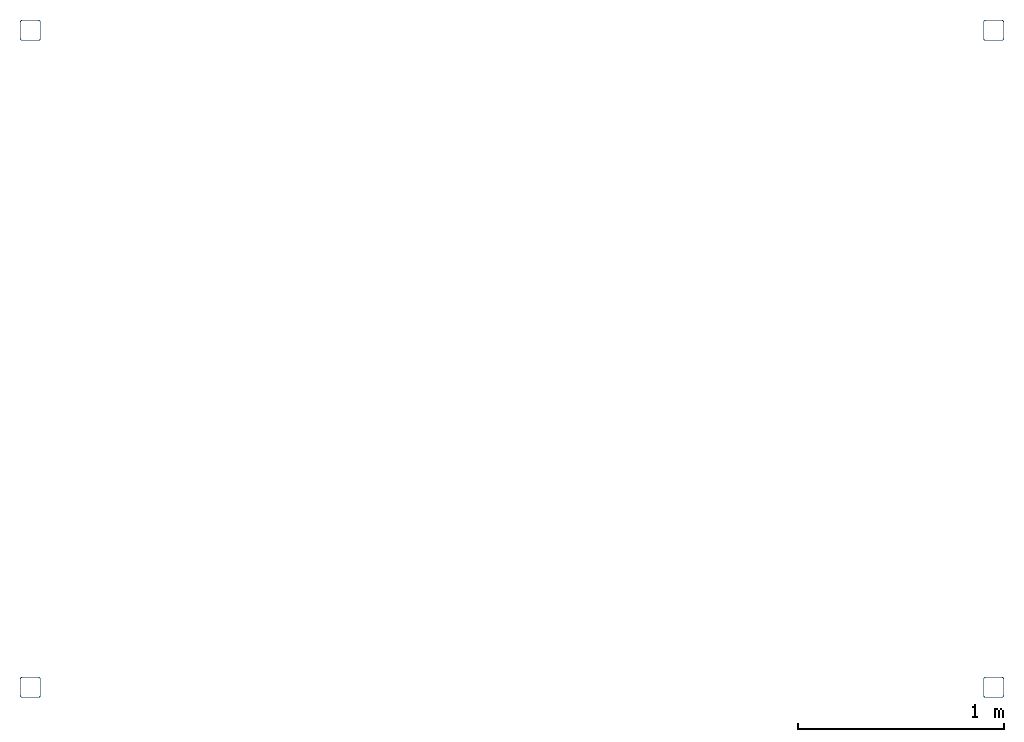
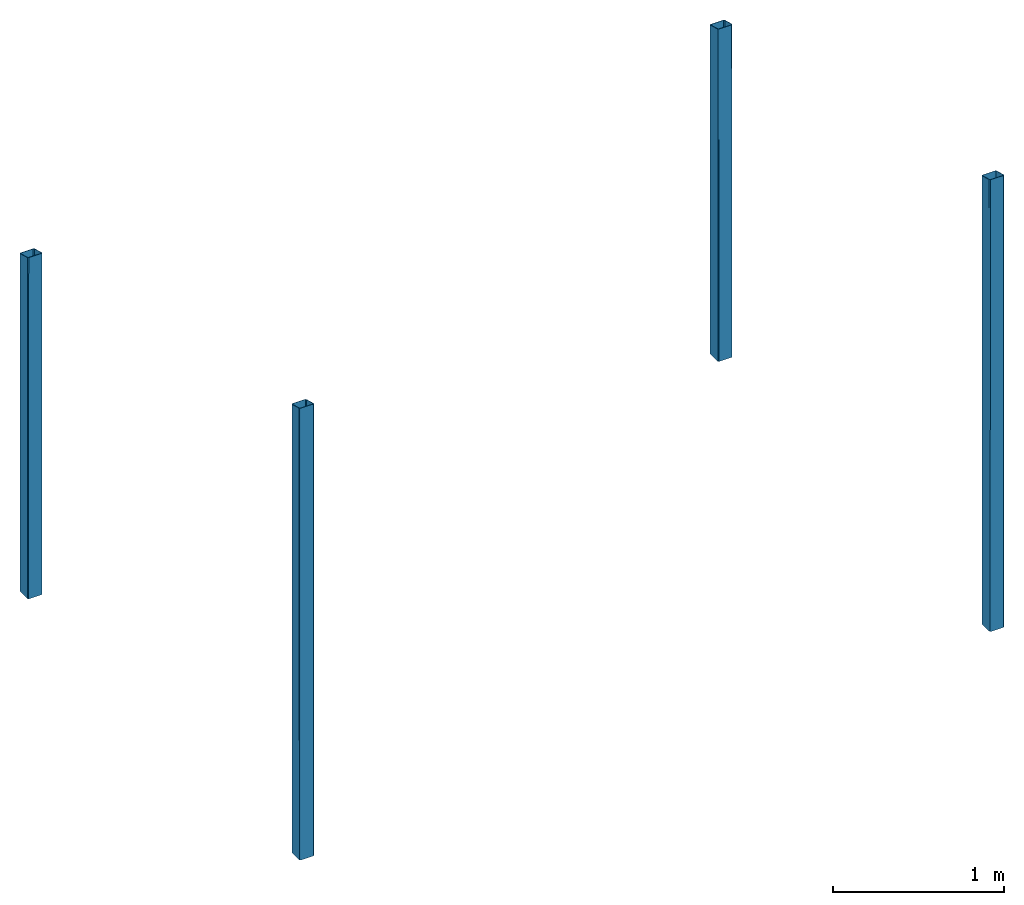
"""IFC4X3_ADD2 building model written with IfcOpenShell, lengths in millimetres."""

import ifcopenshell
import ifcopenshell.guid

model = None  # the IFC model being written
_history = None  # IfcOwnerHistory: only IFC2X3 demands one
_inside = {}  # id of a spatial element -> (the spatial element, [elements in it])
_under = {}  # id of a project, library or spatial element -> (it, [spatial elements below it])
_declared = {}  # id of a project -> (the project, [libraries it declares])
_typed = {}  # id of a type object -> (the type object, [elements of that type])
_made_of = {}  # id of a material, layer set ... -> (it, [elements and type objects made of it])


def new_model(schema):
    """Start an empty IFC model of exactly this schema.

    Asked for "IFC4X3", IfcOpenShell would pick the latest addendum, in which some entities
    have other attributes; the version numbers below select the first issue.
    IFC2X3 requires an IfcOwnerHistory on every rooted entity: one is made here for all.
    """
    global model, _history
    if schema == "IFC4X3":
        model = ifcopenshell.file(schema_version=(4, 3, 0, 0))
    else:
        model = ifcopenshell.file(schema=schema)
    _inside.clear()
    _under.clear()
    _declared.clear()
    _typed.clear()
    _made_of.clear()
    _history = None
    if model.schema == "IFC2X3":
        org = make("IfcOrganization", Name="unknown")
        user = make(
            "IfcPersonAndOrganization",
            ThePerson=make("IfcPerson", FamilyName="unknown"),
            TheOrganization=org,
        )
        app = make(
            "IfcApplication",
            ApplicationDeveloper=org,
            Version="unknown",
            ApplicationFullName="unknown",
            ApplicationIdentifier="unknown",
        )
        _history = make(
            "IfcOwnerHistory",
            OwningUser=user,
            OwningApplication=app,
            ChangeAction="ADDED",
            CreationDate=0,
        )
    return model


def make(cls, **values):
    """One entity of the class cls with the attributes given. An attribute that is None is left unset."""
    return model.create_entity(
        cls, **{name: value for name, value in values.items() if value is not None}
    )


def entity(cls, *values):
    """Any entity or typed value of the class cls, its attributes in the order of the schema. None: left unset."""
    e = model.create_entity(cls)
    for i, value in enumerate(values):
        if value is not None:
            e[i] = value
    return e


def rooted(cls, **values):
    """An entity with a GlobalId (a new one), such as an element, a storey or a relation."""
    return make(cls, GlobalId=ifcopenshell.guid.new(), OwnerHistory=_history, **values)


def si_unit(unit_type, name, prefix=None):
    """IfcSIUnit, for example si_unit("LENGTHUNIT", "METRE", prefix="MILLI")."""
    return make("IfcSIUnit", UnitType=unit_type, Prefix=prefix, Name=name)


def converted_unit(unit_type, name, factor, base, dimensions=None, offset=None):
    """IfcConversionBasedUnit, such as the inch: factor (a typed value) times the base unit."""
    return make(
        "IfcConversionBasedUnit"
        if offset is None
        else "IfcConversionBasedUnitWithOffset",
        ConversionOffset=offset,
        Dimensions=None
        if dimensions is None
        else entity("IfcDimensionalExponents", *dimensions),
        UnitType=unit_type,
        Name=name,
        ConversionFactor=make(
            "IfcMeasureWithUnit", ValueComponent=factor, UnitComponent=base
        ),
    )


def assignment(units):
    """IfcUnitAssignment: the units of a project."""
    return None if units is None else make("IfcUnitAssignment", Units=units)


def point(xyz):
    """IfcCartesianPoint."""
    return None if xyz is None else make("IfcCartesianPoint", Coordinates=xyz)


def direction(xyz):
    """IfcDirection."""
    return None if xyz is None else make("IfcDirection", DirectionRatios=xyz)


def frame(location, z_axis=None, x_axis=None):
    """IfcAxis2Placement3D, a coordinate frame: its origin and axes. An axis left out is left unset."""
    return make(
        "IfcAxis2Placement3D",
        Location=point(location),
        Axis=direction(z_axis),
        RefDirection=direction(x_axis),
    )


def frame_2d(location, x_axis=None):
    """IfcAxis2Placement2D, a coordinate frame in the plane: its origin and x axis."""
    return make(
        "IfcAxis2Placement2D", Location=point(location), RefDirection=direction(x_axis)
    )


def origin_with_axes():
    """The frame at (0, 0, 0) with the z axis (0, 0, 1) and the x axis (1, 0, 0) written out."""
    return frame((0.0, 0.0, 0.0), z_axis=(0.0, 0.0, 1.0), x_axis=(1.0, 0.0, 0.0))


def origin_2d_with_axis():
    """The frame at (0, 0) in the plane with the x axis (1, 0) written out."""
    return frame_2d((0.0, 0.0), x_axis=(1.0, 0.0))


def place(relative_to, where):
    """IfcLocalPlacement: puts the frame where relative to a parent placement (None: the world)."""
    return make(
        "IfcLocalPlacement", PlacementRelTo=relative_to, RelativePlacement=where
    )


def context(
    kind, dimensions, precision=None, world=None, true_north=None, identifier=None
):
    """IfcGeometricRepresentationContext, for example the 3D "Model" context."""
    return make(
        "IfcGeometricRepresentationContext",
        ContextIdentifier=identifier,
        ContextType=kind,
        CoordinateSpaceDimension=dimensions,
        Precision=precision,
        WorldCoordinateSystem=world,
        TrueNorth=true_north,
    )


def subcontext(parent, identifier, kind, view, scale=None):
    """IfcGeometricRepresentationSubContext, for example "Body" below "Model"."""
    return make(
        "IfcGeometricRepresentationSubContext",
        ContextIdentifier=identifier,
        ContextType=kind,
        ParentContext=parent,
        TargetScale=scale,
        TargetView=view,
    )


def project(units=None, contexts=None):
    """IfcProject with its units and contexts."""
    return rooted(
        "IfcProject",
        Name="project",
        RepresentationContexts=contexts,
        UnitsInContext=assignment(units),
    )


def spatial(cls, under=None, at=None, **own):
    """A site, building, storey or space (cls), placed at a placement, below another one or the project."""
    s = rooted(cls, ObjectPlacement=at, **own)
    if under is not None:
        _under.setdefault(under.id(), (under, []))[1].append(s)
    return s


def profile(cls, at=None, kind="AREA", **sizes):
    """A parametric profile (cls). Its sizes go by their IFC names, for example OverallWidth=200.0."""
    return make(cls, ProfileType=kind, Position=at, **sizes)


def hollow_rectangle(**sizes):
    """IfcRectangleHollowProfileDef."""
    return profile("IfcRectangleHollowProfileDef", **sizes)


def extrude(swept, where, along, depth):
    """IfcExtrudedAreaSolid: the profile swept, set in the frame where, extruded along a direction by depth."""
    return make(
        "IfcExtrudedAreaSolid",
        SweptArea=swept,
        Position=where,
        ExtrudedDirection=direction(along),
        Depth=depth,
    )


def clip(a, b, op="DIFFERENCE"):
    """IfcBooleanClippingResult: the solid a cut by the half space b."""
    return make(
        "IfcBooleanClippingResult", Operator=op, FirstOperand=a, SecondOperand=b
    )


def halfspace(plane, agree):
    """IfcHalfSpaceSolid: all space on one side of the plane z = 0 of the frame plane."""
    return make(
        "IfcHalfSpaceSolid",
        BaseSurface=make("IfcPlane", Position=plane),
        AgreementFlag=agree,
    )


def shape(context_of_items, identifier, shape_type, items):
    """IfcShapeRepresentation: the items that make up one representation, for example the "Body"."""
    return make(
        "IfcShapeRepresentation",
        ContextOfItems=context_of_items,
        RepresentationIdentifier=identifier,
        RepresentationType=shape_type,
        Items=items,
    )


def made_of(thing, what):
    """Note that an element or type object is made of a material, layer set ...; save() writes the relation."""
    if what is not None:
        _made_of.setdefault(what.id(), (what, []))[1].append(thing)
    return thing


def element(
    cls,
    number,
    at=None,
    inside=None,
    cuts=None,
    type_object=None,
    material=None,
    context=None,
    identifier="Body",
    shape_type=None,
    held_by="IfcProductDefinitionShape",
    body=None,
    shapes=None,
    **own,
):
    """One element of the class cls, such as IfcWall. Its Tag is "e" and its number.

    at: its placement. inside: the storey or other place that contains it. cuts: it is an
    opening in that element (IfcRelVoidsElement). A single representation is given by context,
    identifier, shape_type and body (its items); several are given by shapes. held_by: the class
    of the entity that holds the representations. save() writes the other relations.
    """
    e = rooted(cls, Tag="e%d" % number, ObjectPlacement=at, **own)
    if body is not None:
        shapes = [shape(context, identifier, shape_type, body)]
    if shapes is not None:
        e.Representation = make(held_by, Representations=shapes)
    if inside is not None:
        _inside.setdefault(inside.id(), (inside, []))[1].append(e)
    if cuts is not None:
        rooted(
            "IfcRelVoidsElement", RelatingBuildingElement=cuts, RelatedOpeningElement=e
        )
    if type_object is not None:
        _typed.setdefault(type_object.id(), (type_object, []))[1].append(e)
    return made_of(e, material)


def aggregate(whole, parts):
    """IfcRelAggregates: a whole, such as a stair, and the parts it consists of."""
    return rooted("IfcRelAggregates", RelatingObject=whole, RelatedObjects=parts)


def save(model, path):
    """Write the relations noted so far, then the file.

    IfcRelAggregates (storeys below a building ...), IfcRelContainedInSpatialStructure (elements
    in a storey), IfcRelDefinesByType, IfcRelAssociatesMaterial and IfcRelDeclares: one each for
    every whole, place, type object, material and project.
    """
    for whole, parts in _under.values():
        aggregate(whole, parts)
    for where, things in _inside.values():
        rooted(
            "IfcRelContainedInSpatialStructure",
            RelatedElements=things,
            RelatingStructure=where,
        )
    for kind, things in _typed.values():
        rooted("IfcRelDefinesByType", RelatedObjects=things, RelatingType=kind)
    for what, things in _made_of.values():
        rooted("IfcRelAssociatesMaterial", RelatedObjects=things, RelatingMaterial=what)
    for by, libraries in _declared.values():
        rooted("IfcRelDeclares", RelatingContext=by, RelatedDefinitions=libraries)
    model.write(path)


model = new_model("IFC4X3_ADD2")

# Units and contexts
model_context = context("Model", 3, precision=1e-05, world=origin_with_axes(), true_north=direction((0.0, 1.0, 0.0)))
plan_context = context("Plan", 2, precision=1e-05, world=origin_2d_with_axis(), true_north=direction((0.0, 1.0)))
body_context = subcontext(model_context, "Body", "Model", "MODEL_VIEW")
ifc_project = project(units=[si_unit("AREAUNIT", "SQUARE_METRE"), si_unit("VOLUMEUNIT", "CUBIC_METRE"), si_unit("LENGTHUNIT", "METRE", prefix="MILLI"), converted_unit("PLANEANGLEUNIT", "degree", entity("IfcReal", 0.0174532925199433), si_unit("PLANEANGLEUNIT", "RADIAN"), dimensions=[0, 0, 0, 0, 0, 0, 0])], contexts=[model_context, plan_context])

# Site, building, storeys
site_placement = place(None, origin_with_axes())
site = spatial("IfcSite", under=ifc_project, at=site_placement)
building_placement = place(site_placement, origin_with_axes())
building = spatial("IfcBuilding", under=site, at=building_placement, Name="Simple 1Bed House")
storey_1_placement = place(building_placement, origin_with_axes())
storey_1 = spatial("IfcBuildingStorey", under=building, at=storey_1_placement, Name="Outside")
storey_2_placement = place(storey_1_placement, frame((0.0, 0.0, 1.00000004749745), z_axis=(0.0, 0.0, 1.0), x_axis=(1.0, 0.0, 0.0)))
storey_2 = spatial("IfcBuildingStorey", under=storey_1, at=storey_2_placement)

# Beams
beam_1_placement = place(storey_2_placement, frame((3318.75705718994, 7331.11095428467, -600.999845075421), z_axis=(1.62921608647796e-07, -2.9406271550997e-06, 0.999999999995663), x_axis=(-0.999999999999975, -1.50995802528083e-07, 1.62921168112003e-07)))
element("IfcBeam", 1, at=beam_1_placement, inside=storey_2, PredefinedType="BEAM", context=body_context, shape_type="Clipping", body=[
    clip(extrude(hollow_rectangle(XDim=100.0, YDim=100.0, WallThickness=3.0, InnerFilletRadius=10.0, OuterFilletRadius=10.0, kind="CURVE"), origin_with_axes(), (0.0, 0.0, 1.0), 3317.87651910655), halfspace(frame((-0.000750061701637605, -3520.37715911865, 2274.58310127258), z_axis=(2.07696075449348e-07, -0.258822023868561, 0.965924978256226), x_axis=(-0.999999999999678, -8.0246677753651e-07, 0.0)), False)),
])
beam_2_placement = place(storey_2_placement, frame((3318.75705718994, 10514.8239135742, -664.213372278027), z_axis=(1.62921608647796e-07, -2.9406271550997e-06, 0.999999999995663), x_axis=(-0.999999999999975, -1.50995802528083e-07, 1.62921168112003e-07)))
element("IfcBeam", 2, at=beam_2_placement, inside=storey_2, PredefinedType="BEAM", context=body_context, shape_type="Clipping", body=[
    clip(extrude(hollow_rectangle(XDim=100.0, YDim=100.0, WallThickness=3.0, InnerFilletRadius=10.0, OuterFilletRadius=10.0, kind="CURVE"), origin_with_axes(), (0.0, 0.0, 1.0), 2528.01608499354), halfspace(frame((-0.00027322454343448, -336.664140224457, 2337.80598640442), z_axis=(2.07696075449348e-07, -0.258822023868561, 0.965924978256226), x_axis=(-0.999999999999678, -8.0246677753651e-07, 0.0)), False)),
])
beam_3_placement = place(storey_2_placement, frame((7987.10536956787, 7331.10618591309, -600.999785470776), z_axis=(1.62921608647796e-07, -2.9406271550997e-06, 0.999999999995663), x_axis=(-0.999999999999975, -1.50995802528083e-07, 1.62921168112003e-07)))
element("IfcBeam", 3, at=beam_3_placement, inside=storey_2, PredefinedType="BEAM", context=body_context, shape_type="Clipping", body=[
    clip(extrude(hollow_rectangle(XDim=100.0, YDim=100.0, WallThickness=3.0, InnerFilletRadius=10.0, OuterFilletRadius=10.0, kind="CURVE"), origin_with_axes(), (0.0, 0.0, 1.0), 3317.87781256182), halfspace(frame((-0.00206136382985278, -3520.38216590881, 2274.58310127258), z_axis=(2.07696075449348e-07, -0.258822023868561, 0.965924978256226), x_axis=(-0.999999999999678, -8.0246677753651e-07, 0.0)), False)),
])
beam_4_placement = place(storey_2_placement, frame((7987.10536956787, 10514.8239135742, -600.999785470776), z_axis=(1.62921608647796e-07, -2.9406271550997e-06, 0.999999999995663), x_axis=(-0.999999999999975, -1.50995802528083e-07, 1.62921168112003e-07)))
element("IfcBeam", 4, at=beam_4_placement, inside=storey_2, PredefinedType="BEAM", context=body_context, shape_type="Clipping", body=[
    clip(extrude(hollow_rectangle(XDim=100.0, YDim=100.0, WallThickness=3.0, InnerFilletRadius=10.0, OuterFilletRadius=10.0, kind="CURVE"), origin_with_axes(), (0.0, 0.0, 1.0), 2464.80225349175), halfspace(frame((-0.00158452667164966, -336.664408445358, 2274.59239959717), z_axis=(2.07696075449348e-07, -0.258822023868561, 0.965924978256226), x_axis=(-0.999999999999678, -8.0246677753651e-07, 0.0)), False)),
])

save(model, "model.ifc")
